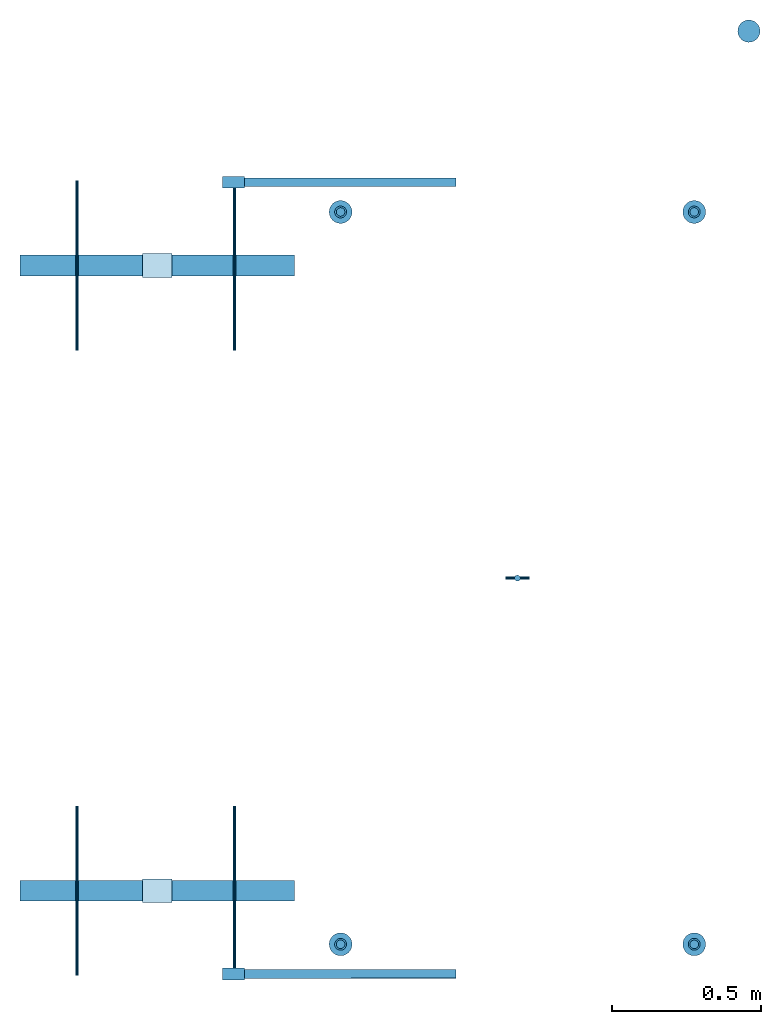
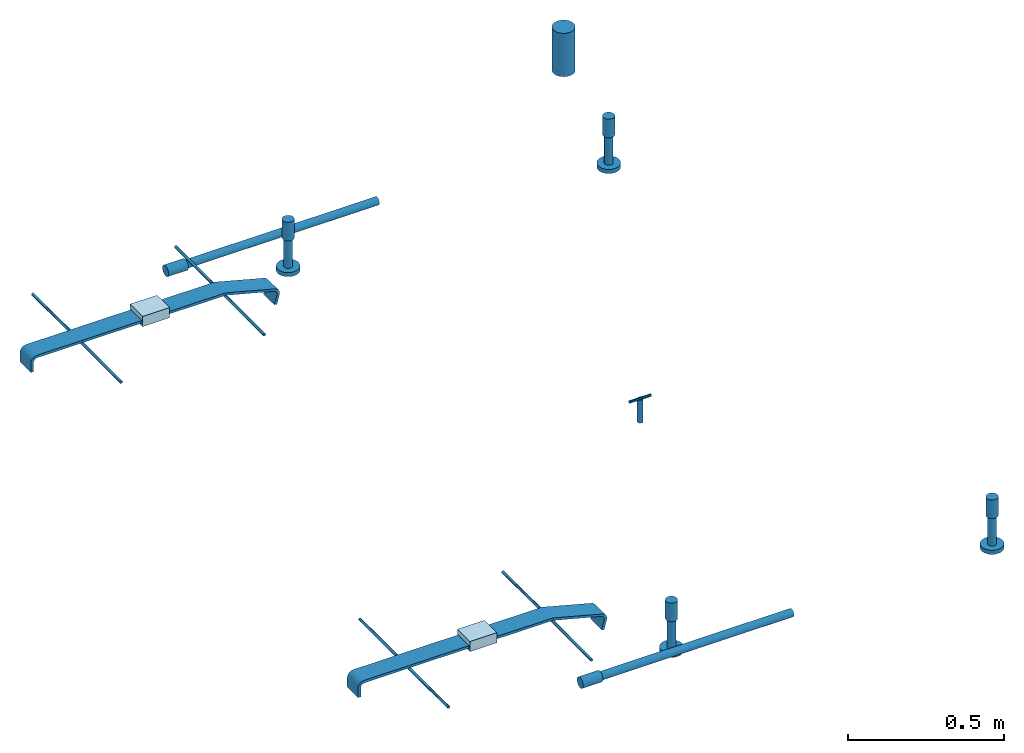
# One storey: 14 reinforcing bars, 6 columns, 5 discrete accessories, 2 beams, 2 plates, 10 elements without a shape of their own.
"""IFC2X3 building model written with IfcOpenShell, lengths in millimetres."""

from ifc_helpers import new_model, entity, si_unit, frame, frame_2d, origin_with_axes, origin_2d_with_axis, place, context, subcontext, project, spatial, polyline, circle_curve, parameter, trimmed, segment, composite_curve, circle, outline, extrude, source, transform, mapped, material, type_object, element, aggregate, save


model = new_model("IFC2X3")

# Units and contexts
model_context = context("Model", 3, precision=1e-05, world=origin_with_axes())
body_context = subcontext(model_context, "Body", "Model", "MODEL_VIEW")
ifc_project = project(units=[si_unit("LENGTHUNIT", "METRE", prefix="MILLI"), si_unit("AREAUNIT", "SQUARE_METRE"), si_unit("VOLUMEUNIT", "CUBIC_METRE"), si_unit("MASSUNIT", "GRAM", prefix="KILO"), si_unit("TIMEUNIT", "SECOND"), si_unit("PLANEANGLEUNIT", "RADIAN"), si_unit("SOLIDANGLEUNIT", "STERADIAN"), si_unit("THERMODYNAMICTEMPERATUREUNIT", "DEGREE_CELSIUS"), si_unit("LUMINOUSINTENSITYUNIT", "LUMEN")], contexts=[model_context])

# Site, building, storey
site_placement = place(None, origin_with_axes())
site = spatial("IfcSite", under=ifc_project, at=site_placement, CompositionType="ELEMENT")
building_placement = place(site_placement, origin_with_axes())
building = spatial("IfcBuilding", under=site, at=building_placement, Name="Undefined", CompositionType="ELEMENT")
storey_placement = place(building_placement, origin_with_axes())
storey = spatial("IfcBuildingStorey", under=building, at=storey_placement, Name="Undefined", CompositionType="ELEMENT", Elevation=0.0)

# Assembly, column
assembly_1_placement = place(storey_placement, origin_with_axes())
assembly_1 = element("IfcElementAssembly", 1, at=assembly_1_placement, inside=storey, Name="Steel Assembly", AssemblyPlace="NOTDEFINED", PredefinedType="RIGID_FRAME")
ifc_material_1 = material(Name="STEEL/Steel_Undefined")
column_type_1 = type_object("IfcColumnType", Name="D40", PredefinedType="NOTDEFINED")
column_1_placement = place(assembly_1_placement, frame((8784.0, 6820.0, -99.0000999999924), z_axis=(0.0, 0.0, 1.0), x_axis=(-0.895962645867593, -0.444129414934366, 0.0)))
column_1 = element("IfcColumn", 2, at=column_1_placement, type_object=column_type_1, material=ifc_material_1, Name="PLA30", ObjectType="D40", context=body_context, shape_type="SweptSolid", body=[
    extrude(circle(Radius=20.0, at=origin_2d_with_axis()), frame((0.0, -4.54747350886464e-13, 72.9999999999995), z_axis=(0.0, 0.0, -1.0), x_axis=(0.0, 1.0, 0.0)), (0.0, 0.0, 1.0), 73.0),
])

assembly_2_placement = place(storey_placement, origin_with_axes())
assembly_2 = element("IfcElementAssembly", 3, at=assembly_2_placement, inside=storey, Name="Steel Assembly", AssemblyPlace="NOTDEFINED", PredefinedType="RIGID_FRAME")
column_2_placement = place(assembly_2_placement, frame((7596.0, 6820.0, -87.0000999999942), z_axis=(0.0, 0.0, 1.0), x_axis=(-0.904917903898717, 0.425586168952366, 0.0)))
column_2 = element("IfcColumn", 4, at=column_2_placement, type_object=column_type_1, material=ifc_material_1, Name="PLA30", ObjectType="D40", context=body_context, shape_type="SweptSolid", body=[
    extrude(circle(Radius=20.0, at=origin_2d_with_axis()), frame((0.0, -4.54747350886464e-13, 72.9999999999995), z_axis=(0.0, 0.0, -1.0), x_axis=(0.0, 1.0, 0.0)), (0.0, 0.0, 1.0), 73.0),
])

assembly_3_placement = place(storey_placement, origin_with_axes())
assembly_3 = element("IfcElementAssembly", 5, at=assembly_3_placement, inside=storey, Name="Steel Assembly", AssemblyPlace="NOTDEFINED", PredefinedType="RIGID_FRAME")
column_3_placement = place(assembly_3_placement, frame((8784.0, 9280.0, -99.0000999999924), z_axis=(0.0, 0.0, 1.0), x_axis=(0.896017803814749, -0.4440181249082, 0.0)))
column_3 = element("IfcColumn", 6, at=column_3_placement, type_object=column_type_1, material=ifc_material_1, Name="PLA30", ObjectType="D40", context=body_context, shape_type="SweptSolid", body=[
    extrude(circle(Radius=20.0, at=origin_2d_with_axis()), frame((0.0, -4.54747350886464e-13, 72.9999999999995), z_axis=(0.0, 0.0, -1.0), x_axis=(0.0, 1.0, 0.0)), (0.0, 0.0, 1.0), 73.0),
])

assembly_4_placement = place(storey_placement, origin_with_axes())
assembly_4 = element("IfcElementAssembly", 7, at=assembly_4_placement, inside=storey, Name="Steel Assembly", AssemblyPlace="NOTDEFINED", PredefinedType="RIGID_FRAME")
column_4_placement = place(assembly_4_placement, frame((7596.0, 9280.0, -87.0000999999942), z_axis=(0.0, 0.0, 1.0), x_axis=(0.904969058279665, 0.425477383131485, 0.0)))
column_4 = element("IfcColumn", 8, at=column_4_placement, type_object=column_type_1, material=ifc_material_1, Name="PLA30", ObjectType="D40", context=body_context, shape_type="SweptSolid", body=[
    extrude(circle(Radius=20.0, at=origin_2d_with_axis()), frame((0.0, -4.54747350886464e-13, 72.9999999999995), z_axis=(0.0, 0.0, -1.0), x_axis=(0.0, 1.0, 0.0)), (0.0, 0.0, 1.0), 73.0),
])

assembly_5_placement = place(storey_placement, origin_with_axes())
assembly_5 = element("IfcElementAssembly", 9, at=assembly_5_placement, inside=storey, Name="Steel Assembly", AssemblyPlace="NOTDEFINED", PredefinedType="RIGID_FRAME")
ifc_material_2 = material(Name="STEEL/1.4305")
column_type_2 = type_object("IfcColumnType", Name="D20", PredefinedType="NOTDEFINED")
column_5_placement = place(assembly_5_placement, frame((8190.0, 8050.0, -270.0), z_axis=(0.0, 0.0, 1.0), x_axis=(0.0, 1.0, 0.0)))
column_5 = element("IfcColumn", 10, at=column_5_placement, type_object=column_type_2, material=ifc_material_2, Name="M16x90", ObjectType="D20", context=body_context, shape_type="SweptSolid", body=[
    extrude(circle(Radius=10.0, at=origin_2d_with_axis()), frame((0.0, 0.0, 90.0), z_axis=(0.0, 0.0, -1.0), x_axis=(0.0, 1.0, 0.0)), (0.0, 0.0, 1.0), 90.0),
])

assembly_6_placement = place(storey_placement, origin_with_axes())
assembly_6 = element("IfcElementAssembly", 11, at=assembly_6_placement, inside=storey, Name="Steel Assembly", AssemblyPlace="NOTDEFINED", PredefinedType="RIGID_FRAME")
ifc_material_3 = material(Name="STEEL/1.4301")
column_type_3 = type_object("IfcColumnType", Name="D75", PredefinedType="NOTDEFINED")
column_6_placement = place(assembly_6_placement, frame((8967.49878393828, 9887.49662337208, -280.054915765766), z_axis=(-2.04100000067167e-05, -2.86890000063952e-05, 0.999999999380187), x_axis=(0.981183268554412, 0.193078721912338, 2.55651859878299e-05)))
column_6 = element("IfcColumn", 12, at=column_6_placement, type_object=column_type_3, material=ifc_material_3, Name="83/75", ObjectType="D75", context=body_context, shape_type="SweptSolid", body=[
    extrude(circle(Radius=37.5, at=origin_2d_with_axis()), frame((-1.81898940354586e-12, -1.72790510903002e-18, 169.995857759637), z_axis=(0.0, 0.0, -1.0), x_axis=(0.0, 1.0, 0.0)), (0.0, 0.0, 1.0), 170.0),
])
aggregate(assembly_6, [column_6])

# Assembly, beam
assembly_7_placement = place(storey_placement, origin_with_axes())
assembly_7 = element("IfcElementAssembly", 13, at=assembly_7_placement, inside=storey, Name="Steel Assembly", AssemblyPlace="NOTDEFINED", PredefinedType="RIGID_FRAME")
beam_type = type_object("IfcBeamType", Name="D40", PredefinedType="NOTDEFINED")
beam_1_placement = place(assembly_7_placement, frame((7272.9993687735, 9380.02551493117, -140.00442402613), z_axis=(1.19564911619818e-06, 2.6939999552269e-06, 0.999999999995656), x_axis=(-0.999999991516754, -0.000130249999939832, 1.19599999947828e-06)))
beam_1 = element("IfcBeam", 14, at=beam_1_placement, type_object=beam_type, material=ifc_material_1, Name="PLA30P RST", ObjectType="D40", context=body_context, shape_type="SweptSolid", body=[
    extrude(circle(Radius=20.0, at=origin_2d_with_axis()), frame((73.000000000254, -8.95263087333074e-19, 0.0), z_axis=(-1.0, 1.22638779086296e-20, 0.0), x_axis=(1.2058821935041e-20, -1.0, -4.2351647362715e-22)), (0.0, 0.0, 1.0), 73.0),
])

assembly_8_placement = place(storey_placement, origin_with_axes())
assembly_8 = element("IfcElementAssembly", 15, at=assembly_8_placement, inside=storey, Name="Steel Assembly", AssemblyPlace="NOTDEFINED", PredefinedType="RIGID_FRAME")
beam_2_placement = place(assembly_8_placement, frame((7272.99936877345, 6720.02551493114, -140.004424026123), z_axis=(1.19564911619818e-06, 2.6939999552269e-06, 0.999999999995656), x_axis=(-0.999999991516754, -0.000130249999939832, 1.19599999947828e-06)))
beam_2 = element("IfcBeam", 16, at=beam_2_placement, type_object=beam_type, material=ifc_material_1, Name="PLA30P RST", ObjectType="D40", context=body_context, shape_type="SweptSolid", body=[
    extrude(circle(Radius=20.0, at=origin_2d_with_axis()), frame((73.000000000254, -8.95263087333074e-19, 0.0), z_axis=(-1.0, 1.22638779086296e-20, 0.0), x_axis=(1.2058821935041e-20, -1.0, -4.2351647362715e-22)), (0.0, 0.0, 1.0), 73.0),
])

# Assembly, plate
assembly_9_placement = place(storey_placement, origin_with_axes())
assembly_9 = element("IfcElementAssembly", 17, at=assembly_9_placement, inside=storey, Name="Steel Assembly", AssemblyPlace="NOTDEFINED", PredefinedType="RIGID_FRAME")
plate_type = type_object("IfcPlateType", Name="PL80X40", PredefinedType="NOTDEFINED")
plate_1_placement = place(assembly_9_placement, frame((7030.0, 9100.0, -69.9999999999964), z_axis=(1.2058821935041e-20, -1.0, -4.2351647362715e-22), x_axis=(0.0, 0.0, 1.0)))
plate_1 = element("IfcPlate", 18, at=plate_1_placement, type_object=plate_type, material=ifc_material_1, Name="PS230", ObjectType="PL80X40", context=body_context, shape_type="SweptSolid", body=[
    extrude(outline(polyline([(0.0, 0.0), (40.0, 0.0), (40.0, 100.0), (0.0, 100.0), (0.0, 0.0)])), frame((0.0, 0.0, -40.0), z_axis=(0.0, 0.0, 1.0), x_axis=(1.0, 0.0, 0.0)), (0.0, 0.0, 1.0), 80.0),
])

assembly_10_placement = place(storey_placement, origin_with_axes())
assembly_10 = element("IfcElementAssembly", 19, at=assembly_10_placement, inside=storey, Name="Steel Assembly", AssemblyPlace="NOTDEFINED", PredefinedType="RIGID_FRAME")
plate_2_placement = place(assembly_10_placement, frame((7030.0, 7000.0, -69.9999999999964), z_axis=(1.2058821935041e-20, -1.0, -4.2351647362715e-22), x_axis=(0.0, 0.0, 1.0)))
plate_2 = element("IfcPlate", 20, at=plate_2_placement, type_object=plate_type, material=ifc_material_1, Name="PS230", ObjectType="PL80X40", context=body_context, shape_type="SweptSolid", body=[
    extrude(outline(polyline([(0.0, 0.0), (40.0, 0.0), (40.0, 100.0), (0.0, 100.0), (0.0, 0.0)])), frame((0.0, 0.0, -40.0), z_axis=(0.0, 0.0, 1.0), x_axis=(1.0, 0.0, 0.0)), (0.0, 0.0, 1.0), 80.0),
])

# Reinforcing bar
ifc_material_4 = material(Name="Undefined")
shared_shape_1 = source(origin_with_axes(), body_context, "Body", "AdvancedSweptSolid", [
    entity("IfcSweptDiskSolid", entity("IfcTrimmedCurve", entity("IfcLine", entity("IfcCartesianPoint", [0.0, 0.0, 0.0]), entity("IfcVector", entity("IfcDirection", [1.0, 0.0, 0.0]), 1.0)), [entity("IfcParameterValue", 0.0)], [entity("IfcParameterValue", 711.000000000276)], True, "PARAMETER"), 14.5, None, 0.0, 711.000000000276),
])
reinforcing_bar_1_placement = place(assembly_7_placement, frame((7272.99936895076, 9380.02468352953, -140.003886127926), z_axis=(0.000130155301525519, -0.999548757077827, -0.0300377310023403), x_axis=(0.999999991516754, 0.000130249999937964, -1.19599999942144e-06)))
reinforcing_bar_1 = element("IfcReinforcingBar", 21, at=reinforcing_bar_1_placement, material=ifc_material_4, Name="REBAR", BarRole="NOTDEFINED", CrossSectionArea=0.0, NominalDiameter=29.0, context=body_context, shape_type="MappedRepresentation", body=[
    mapped(shared_shape_1, transform((0.0, 0.0, 0.0))),
])

aggregate(assembly_7, [beam_1, reinforcing_bar_1])

shared_shape_2 = source(origin_with_axes(), body_context, "Body", "AdvancedSweptSolid", [
    entity("IfcSweptDiskSolid", entity("IfcTrimmedCurve", entity("IfcLine", entity("IfcCartesianPoint", [0.0, 0.0, 0.0]), entity("IfcVector", entity("IfcDirection", [1.0, 0.0, 0.0]), 1.0)), [entity("IfcParameterValue", 0.0)], [entity("IfcParameterValue", 111.0)], True, "PARAMETER"), 14.5, None, 0.0, 111.0),
])
reinforcing_bar_2_placement = place(assembly_1_placement, frame((8784.0, 6820.0, -99.0000999999924), z_axis=(0.444129414934365, -0.895962645867593, 0.0), x_axis=(0.0, 0.0, -1.0)))
reinforcing_bar_2 = element("IfcReinforcingBar", 22, at=reinforcing_bar_2_placement, material=ifc_material_4, Name="REBAR", BarRole="NOTDEFINED", CrossSectionArea=0.0, NominalDiameter=29.0, context=body_context, shape_type="MappedRepresentation", body=[
    mapped(shared_shape_2, transform((0.0, 0.0, 0.0))),
])

shared_shape_3 = source(origin_with_axes(), body_context, "Body", "AdvancedSweptSolid", [
    entity("IfcSweptDiskSolid", entity("IfcTrimmedCurve", entity("IfcLine", entity("IfcCartesianPoint", [0.0, 0.0, 0.0]), entity("IfcVector", entity("IfcDirection", [1.0, 0.0, 0.0]), 1.0)), [entity("IfcParameterValue", 0.0)], [entity("IfcParameterValue", 16.0)], True, "PARAMETER"), 38.5, None, 0.0, 16.0),
])
reinforcing_bar_3_placement = place(assembly_1_placement, frame((8784.0, 6820.0, -226.000099999992), z_axis=(-0.444129414934365, 0.895962645867593, 0.0), x_axis=(0.0, 0.0, 1.0)))
reinforcing_bar_3 = element("IfcReinforcingBar", 23, at=reinforcing_bar_3_placement, material=ifc_material_4, Name="REBAR", BarRole="NOTDEFINED", CrossSectionArea=0.0, NominalDiameter=77.0, context=body_context, shape_type="MappedRepresentation", body=[
    mapped(shared_shape_3, transform((0.0, 0.0, 0.0))),
])

aggregate(assembly_1, [column_1, reinforcing_bar_2, reinforcing_bar_3])

shared_shape_4 = source(origin_with_axes(), body_context, "Body", "AdvancedSweptSolid", [
    entity("IfcSweptDiskSolid", entity("IfcTrimmedCurve", entity("IfcLine", entity("IfcCartesianPoint", [0.0, 0.0, 0.0]), entity("IfcVector", entity("IfcDirection", [1.0, 0.0, 0.0]), 1.0)), [entity("IfcParameterValue", 0.0)], [entity("IfcParameterValue", 111.0)], True, "PARAMETER"), 14.5, None, 0.0, 111.0),
])
reinforcing_bar_4_placement = place(assembly_2_placement, frame((7596.0, 6820.0, -87.0000999999942), z_axis=(-0.425586168952366, -0.904917903898717, 0.0), x_axis=(0.0, 0.0, -1.0)))
reinforcing_bar_4 = element("IfcReinforcingBar", 24, at=reinforcing_bar_4_placement, material=ifc_material_4, Name="REBAR", BarRole="NOTDEFINED", CrossSectionArea=0.0, NominalDiameter=29.0, context=body_context, shape_type="MappedRepresentation", body=[
    mapped(shared_shape_4, transform((0.0, 0.0, 0.0))),
])

shared_shape_5 = source(origin_with_axes(), body_context, "Body", "AdvancedSweptSolid", [
    entity("IfcSweptDiskSolid", entity("IfcTrimmedCurve", entity("IfcLine", entity("IfcCartesianPoint", [0.0, 0.0, 0.0]), entity("IfcVector", entity("IfcDirection", [1.0, 0.0, 0.0]), 1.0)), [entity("IfcParameterValue", 0.0)], [entity("IfcParameterValue", 16.0)], True, "PARAMETER"), 38.5, None, 0.0, 16.0),
])
reinforcing_bar_5_placement = place(assembly_2_placement, frame((7596.0, 6820.0, -214.000099999994), z_axis=(0.425586168952366, 0.904917903898717, 0.0), x_axis=(0.0, 0.0, 1.0)))
reinforcing_bar_5 = element("IfcReinforcingBar", 25, at=reinforcing_bar_5_placement, material=ifc_material_4, Name="REBAR", BarRole="NOTDEFINED", CrossSectionArea=0.0, NominalDiameter=77.0, context=body_context, shape_type="MappedRepresentation", body=[
    mapped(shared_shape_5, transform((0.0, 0.0, 0.0))),
])

aggregate(assembly_2, [column_2, reinforcing_bar_4, reinforcing_bar_5])

shared_shape_6 = source(origin_with_axes(), body_context, "Body", "AdvancedSweptSolid", [
    entity("IfcSweptDiskSolid", entity("IfcTrimmedCurve", entity("IfcLine", entity("IfcCartesianPoint", [0.0, 0.0, 0.0]), entity("IfcVector", entity("IfcDirection", [1.0, 0.0, 0.0]), 1.0)), [entity("IfcParameterValue", 0.0)], [entity("IfcParameterValue", 111.0)], True, "PARAMETER"), 14.5, None, 0.0, 111.0),
])
reinforcing_bar_6_placement = place(assembly_3_placement, frame((8784.0, 9280.0, -99.0000999999924), z_axis=(0.4440181249082, 0.896017803814749, 0.0), x_axis=(0.0, 0.0, -1.0)))
reinforcing_bar_6 = element("IfcReinforcingBar", 26, at=reinforcing_bar_6_placement, material=ifc_material_4, Name="REBAR", BarRole="NOTDEFINED", CrossSectionArea=0.0, NominalDiameter=29.0, context=body_context, shape_type="MappedRepresentation", body=[
    mapped(shared_shape_6, transform((0.0, 0.0, 0.0))),
])

shared_shape_7 = source(origin_with_axes(), body_context, "Body", "AdvancedSweptSolid", [
    entity("IfcSweptDiskSolid", entity("IfcTrimmedCurve", entity("IfcLine", entity("IfcCartesianPoint", [0.0, 0.0, 0.0]), entity("IfcVector", entity("IfcDirection", [1.0, 0.0, 0.0]), 1.0)), [entity("IfcParameterValue", 0.0)], [entity("IfcParameterValue", 16.0)], True, "PARAMETER"), 38.5, None, 0.0, 16.0),
])
reinforcing_bar_7_placement = place(assembly_3_placement, frame((8784.0, 9280.0, -226.000099999992), z_axis=(-0.4440181249082, -0.896017803814749, 0.0), x_axis=(0.0, 0.0, 1.0)))
reinforcing_bar_7 = element("IfcReinforcingBar", 27, at=reinforcing_bar_7_placement, material=ifc_material_4, Name="REBAR", BarRole="NOTDEFINED", CrossSectionArea=0.0, NominalDiameter=77.0, context=body_context, shape_type="MappedRepresentation", body=[
    mapped(shared_shape_7, transform((0.0, 0.0, 0.0))),
])

aggregate(assembly_3, [column_3, reinforcing_bar_6, reinforcing_bar_7])

shared_shape_8 = source(origin_with_axes(), body_context, "Body", "AdvancedSweptSolid", [
    entity("IfcSweptDiskSolid", entity("IfcTrimmedCurve", entity("IfcLine", entity("IfcCartesianPoint", [0.0, 0.0, 0.0]), entity("IfcVector", entity("IfcDirection", [1.0, 0.0, 0.0]), 1.0)), [entity("IfcParameterValue", 0.0)], [entity("IfcParameterValue", 111.0)], True, "PARAMETER"), 14.5, None, 0.0, 111.0),
])
reinforcing_bar_8_placement = place(assembly_4_placement, frame((7596.0, 9280.0, -87.0000999999942), z_axis=(-0.425477383131486, 0.904969058279664, 0.0), x_axis=(0.0, 0.0, -1.0)))
reinforcing_bar_8 = element("IfcReinforcingBar", 28, at=reinforcing_bar_8_placement, material=ifc_material_4, Name="REBAR", BarRole="NOTDEFINED", CrossSectionArea=0.0, NominalDiameter=29.0, context=body_context, shape_type="MappedRepresentation", body=[
    mapped(shared_shape_8, transform((0.0, 0.0, 0.0))),
])

shared_shape_9 = source(origin_with_axes(), body_context, "Body", "AdvancedSweptSolid", [
    entity("IfcSweptDiskSolid", entity("IfcTrimmedCurve", entity("IfcLine", entity("IfcCartesianPoint", [0.0, 0.0, 0.0]), entity("IfcVector", entity("IfcDirection", [1.0, 0.0, 0.0]), 1.0)), [entity("IfcParameterValue", 0.0)], [entity("IfcParameterValue", 16.0)], True, "PARAMETER"), 38.5, None, 0.0, 16.0),
])
reinforcing_bar_9_placement = place(assembly_4_placement, frame((7596.0, 9280.0, -214.000099999994), z_axis=(0.425477383131486, -0.904969058279664, 0.0), x_axis=(0.0, 0.0, 1.0)))
reinforcing_bar_9 = element("IfcReinforcingBar", 29, at=reinforcing_bar_9_placement, material=ifc_material_4, Name="REBAR", BarRole="NOTDEFINED", CrossSectionArea=0.0, NominalDiameter=77.0, context=body_context, shape_type="MappedRepresentation", body=[
    mapped(shared_shape_9, transform((0.0, 0.0, 0.0))),
])

aggregate(assembly_4, [column_4, reinforcing_bar_8, reinforcing_bar_9])

shared_shape_10 = source(origin_with_axes(), body_context, "Body", "AdvancedSweptSolid", [
    entity("IfcSweptDiskSolid", entity("IfcTrimmedCurve", entity("IfcLine", entity("IfcCartesianPoint", [0.0, 0.0, 0.0]), entity("IfcVector", entity("IfcDirection", [1.0, 0.0, 0.0]), 1.0)), [entity("IfcParameterValue", 0.0)], [entity("IfcParameterValue", 711.000000000277)], True, "PARAMETER"), 14.5, None, 0.0, 711.000000000277),
])
reinforcing_bar_10_placement = place(assembly_8_placement, frame((7272.9993689507, 6720.0246835295, -140.003886127918), z_axis=(0.000130155301525519, -0.999548757077827, -0.0300377310023403), x_axis=(0.999999991516754, 0.000130249999937964, -1.19599999942144e-06)))
reinforcing_bar_10 = element("IfcReinforcingBar", 30, at=reinforcing_bar_10_placement, material=ifc_material_4, Name="REBAR", BarRole="NOTDEFINED", CrossSectionArea=0.0, NominalDiameter=29.0, context=body_context, shape_type="MappedRepresentation", body=[
    mapped(shared_shape_10, transform((0.0, 0.0, 0.0))),
])

aggregate(assembly_8, [beam_2, reinforcing_bar_10])

# Discrete accessory
discrete_accessory_type_1 = type_object("IfcDiscreteAccessoryType", Name="DUMMY")
discrete_accessory_1_placement = place(assembly_5_placement, frame((8230.0, 8050.0, -180.0), z_axis=(0.0, 1.0, 0.0), x_axis=(-1.0, 1.22638779086296e-20, 0.0)))
discrete_accessory_1 = element("IfcDiscreteAccessory", 31, at=discrete_accessory_1_placement, type_object=discrete_accessory_type_1, material=ifc_material_2, Name="DUMMY", ObjectType="D10", context=body_context, shape_type="SweptSolid", body=[
    extrude(circle(Radius=5.0, at=origin_2d_with_axis()), frame((80.0, 0.0, 0.0), z_axis=(-1.0, 1.22638779086296e-20, 0.0), x_axis=(1.2058821935041e-20, -1.0, -4.2351647362715e-22)), (0.0, 0.0, 1.0), 80.0),
])

aggregate(assembly_5, [discrete_accessory_1, column_5])

discrete_accessory_type_2 = type_object("IfcDiscreteAccessoryType", Name="PS200")
discrete_accessory_2_placement = place(assembly_9_placement, frame((6940.0, 9100.0, -48.9999999999982), z_axis=(1.2058821935041e-20, -1.0, -4.2351647362715e-22), x_axis=(-1.0, 1.22638779086296e-20, 0.0)))
discrete_accessory_2 = element("IfcDiscreteAccessory", 32, at=discrete_accessory_2_placement, type_object=discrete_accessory_type_2, material=ifc_material_1, Name="PS200", ObjectType="PL70X60", context=body_context, shape_type="SweptSolid", body=[
    extrude(outline(composite_curve([segment(polyline([(0.0, 0.0), (398.0, 6.87845874214966e-12)]), True, "CONTINUOUS"), segment(trimmed(circle_curve(frame_2d((398.0, 23.0000000000069), x_axis=(1.4828717963689e-14, -1.0)), 23.0), [parameter(0.0)], [parameter(1.57079632679488)], True, "PARAMETER"), True, "CONTINUOUS"), segment(polyline([(421.0, 23.0000000000069), (421.0, 60.0), (411.0, 60.0), (411.0, 25.0)]), True, "CONTINUOUS"), segment(trimmed(circle_curve(frame_2d((396.0, 25.0), x_axis=(1.0, 0.0)), 15.0), [parameter(0.0)], [parameter(4.71238898038469)], False, "PARAMETER"), True, "CONTINUOUS"), segment(polyline([(396.0, 10.0), (0.0, 10.0), (0.0, 0.0)]), True, "CONTINUOUS")], self_intersect=True)), frame((0.0, 0.0, -35.0), z_axis=(0.0, 0.0, 1.0), x_axis=(1.0, 0.0, 0.0)), (0.0, 0.0, 1.0), 70.0),
])

discrete_accessory_3_placement = place(assembly_9_placement, frame((7445.97000094325, 9100.0, -103.76005441519), z_axis=(1.2058821935041e-20, -1.0, -4.2351647362715e-22), x_axis=(-0.966544292860371, 0.0, 0.256499765962945)))
discrete_accessory_3 = element("IfcDiscreteAccessory", 33, at=discrete_accessory_3_placement, type_object=discrete_accessory_type_2, material=ifc_material_1, Name="PS200", ObjectType="PL70X113", context=body_context, shape_type="SweptSolid", body=[
    extrude(outline(composite_curve([segment(trimmed(circle_curve(frame_2d((23.0400457468528, 23.0000000000025), x_axis=(-0.99999848688837, 0.00173960368224458)), 23.0), [parameter(0.0)], [parameter(1.57253593135466)], True, "PARAMETER"), True, "CONTINUOUS"), segment(polyline([(23.0400457468554, 2.5566696094284e-12), (213.099411011284, 2.36468622460961e-11), (425.739166260862, 56.4299736023818), (423.17416381945, 66.0954132080931), (210.534408569874, 9.66544055943109), (25.1344495065232, 8.76145037309022)]), True, "CONTINUOUS"), segment(trimmed(circle_curve(frame_2d((25.0613119951757, 23.7612720688449), x_axis=(0.00487583408983478, -0.999988113050314)), 15.0), [parameter(0.0)], [parameter(4.7066116804416)], False, "PARAMETER"), True, "CONTINUOUS"), segment(polyline([(10.0613180897192, 23.7747937650171), (10.0939512253171, 59.9756393432585), (0.104437835525459, 60.0353279113717), (0.0400805484203027, 23.0400108846942)]), True, "CONTINUOUS")], self_intersect=True)), frame((0.0, 0.0, -35.0), z_axis=(0.0, 0.0, 1.0), x_axis=(1.0, 0.0, 0.0)), (0.0, 0.0, 1.0), 70.0),
])

discrete_accessory_4_placement = place(assembly_10_placement, frame((6940.0, 7000.0, -48.9999999999982), z_axis=(1.2058821935041e-20, -1.0, -4.2351647362715e-22), x_axis=(-1.0, 1.22638779086296e-20, 0.0)))
discrete_accessory_4 = element("IfcDiscreteAccessory", 34, at=discrete_accessory_4_placement, type_object=discrete_accessory_type_2, material=ifc_material_1, Name="PS200", ObjectType="PL70X60", context=body_context, shape_type="SweptSolid", body=[
    extrude(outline(composite_curve([segment(polyline([(0.0, 0.0), (398.0, 6.87845874214966e-12)]), True, "CONTINUOUS"), segment(trimmed(circle_curve(frame_2d((398.0, 23.0000000000069), x_axis=(1.4828717963689e-14, -1.0)), 23.0), [parameter(0.0)], [parameter(1.57079632679488)], True, "PARAMETER"), True, "CONTINUOUS"), segment(polyline([(421.0, 23.0000000000069), (421.0, 60.0), (411.0, 60.0), (411.0, 25.0)]), True, "CONTINUOUS"), segment(trimmed(circle_curve(frame_2d((396.0, 25.0), x_axis=(1.0, 0.0)), 15.0), [parameter(0.0)], [parameter(4.71238898038469)], False, "PARAMETER"), True, "CONTINUOUS"), segment(polyline([(396.0, 10.0), (0.0, 10.0), (0.0, 0.0)]), True, "CONTINUOUS")], self_intersect=True)), frame((0.0, 0.0, -35.0), z_axis=(0.0, 0.0, 1.0), x_axis=(1.0, 0.0, 0.0)), (0.0, 0.0, 1.0), 70.0),
])

discrete_accessory_5_placement = place(assembly_10_placement, frame((7445.97000094325, 7000.0, -103.76005441519), z_axis=(1.2058821935041e-20, -1.0, -4.2351647362715e-22), x_axis=(-0.966544292860371, 0.0, 0.256499765962945)))
discrete_accessory_5 = element("IfcDiscreteAccessory", 35, at=discrete_accessory_5_placement, type_object=discrete_accessory_type_2, material=ifc_material_1, Name="PS200", ObjectType="PL70X113", context=body_context, shape_type="SweptSolid", body=[
    extrude(outline(composite_curve([segment(trimmed(circle_curve(frame_2d((23.0400457468528, 23.0000000000025), x_axis=(-0.99999848688837, 0.00173960368224458)), 23.0), [parameter(0.0)], [parameter(1.57253593135466)], True, "PARAMETER"), True, "CONTINUOUS"), segment(polyline([(23.0400457468554, 2.5566696094284e-12), (213.099411011284, 2.36468622460961e-11), (425.739166260862, 56.4299736023818), (423.17416381945, 66.0954132080931), (210.534408569874, 9.66544055943109), (25.1344495065232, 8.76145037309022)]), True, "CONTINUOUS"), segment(trimmed(circle_curve(frame_2d((25.0613119951757, 23.7612720688449), x_axis=(0.00487583408983478, -0.999988113050314)), 15.0), [parameter(0.0)], [parameter(4.7066116804416)], False, "PARAMETER"), True, "CONTINUOUS"), segment(polyline([(10.0613180897192, 23.7747937650171), (10.0939512253171, 59.9756393432585), (0.104437835525459, 60.0353279113717), (0.0400805484203027, 23.0400108846942)]), True, "CONTINUOUS")], self_intersect=True)), frame((0.0, 0.0, -35.0), z_axis=(0.0, 0.0, 1.0), x_axis=(1.0, 0.0, 0.0)), (0.0, 0.0, 1.0), 70.0),
])

# Reinforcing bar
shared_shape_11 = source(origin_with_axes(), body_context, "Body", "AdvancedSweptSolid", [
    entity("IfcSweptDiskSolid", entity("IfcTrimmedCurve", entity("IfcLine", entity("IfcCartesianPoint", [0.0, 0.0, 0.0]), entity("IfcVector", entity("IfcDirection", [1.0, 0.0, 0.0]), 1.0)), [entity("IfcParameterValue", 0.0)], [entity("IfcParameterValue", 570.000000000002)], True, "PARAMETER"), 5.0, None, 0.0, 570.000000000002),
])
reinforcing_bar_11_placement = place(assembly_9_placement, frame((6769.99677343954, 9135.0, -62.0), z_axis=(0.0, 0.0, -1.0), x_axis=(1.2058821935041e-20, -1.0, -4.2351647362715e-22)))
reinforcing_bar_11 = element("IfcReinforcingBar", 36, at=reinforcing_bar_11_placement, material=ifc_material_4, Name="REBAR", BarRole="NOTDEFINED", CrossSectionArea=0.0, NominalDiameter=10.0, context=body_context, shape_type="MappedRepresentation", body=[
    mapped(shared_shape_11, transform((-250.0, 60.0, 0.0))),
])

shared_shape_12 = source(origin_with_axes(), body_context, "Body", "AdvancedSweptSolid", [
    entity("IfcSweptDiskSolid", entity("IfcTrimmedCurve", entity("IfcLine", entity("IfcCartesianPoint", [0.0, 0.0, 0.0]), entity("IfcVector", entity("IfcDirection", [1.0, 0.0, 0.0]), 1.0)), [entity("IfcParameterValue", 0.0)], [entity("IfcParameterValue", 570.000000000002)], True, "PARAMETER"), 5.0, None, 0.0, 570.000000000002),
])
reinforcing_bar_12_placement = place(assembly_9_placement, frame((7179.99998475582, 9135.0, -62.2001041683143), z_axis=(0.0, 0.0, -1.0), x_axis=(1.2058821935041e-20, -1.0, -4.2351647362715e-22)))
reinforcing_bar_12 = element("IfcReinforcingBar", 37, at=reinforcing_bar_12_placement, material=ifc_material_4, Name="REBAR", BarRole="NOTDEFINED", CrossSectionArea=0.0, NominalDiameter=10.0, context=body_context, shape_type="MappedRepresentation", body=[
    mapped(shared_shape_12, transform((-250.0, -60.0, 0.0))),
])

aggregate(assembly_9, [discrete_accessory_2, reinforcing_bar_11, discrete_accessory_3, reinforcing_bar_12, plate_1])

shared_shape_13 = source(origin_with_axes(), body_context, "Body", "AdvancedSweptSolid", [
    entity("IfcSweptDiskSolid", entity("IfcTrimmedCurve", entity("IfcLine", entity("IfcCartesianPoint", [0.0, 0.0, 0.0]), entity("IfcVector", entity("IfcDirection", [1.0, 0.0, 0.0]), 1.0)), [entity("IfcParameterValue", 0.0)], [entity("IfcParameterValue", 570.000000000002)], True, "PARAMETER"), 5.0, None, 0.0, 570.000000000002),
])
reinforcing_bar_13_placement = place(assembly_10_placement, frame((6769.99677343954, 7035.0, -62.0), z_axis=(0.0, 0.0, -1.0), x_axis=(1.2058821935041e-20, -1.0, -4.2351647362715e-22)))
reinforcing_bar_13 = element("IfcReinforcingBar", 38, at=reinforcing_bar_13_placement, material=ifc_material_4, Name="REBAR", BarRole="NOTDEFINED", CrossSectionArea=0.0, NominalDiameter=10.0, context=body_context, shape_type="MappedRepresentation", body=[
    mapped(shared_shape_13, transform((-250.0, 60.0, 0.0))),
])

shared_shape_14 = source(origin_with_axes(), body_context, "Body", "AdvancedSweptSolid", [
    entity("IfcSweptDiskSolid", entity("IfcTrimmedCurve", entity("IfcLine", entity("IfcCartesianPoint", [0.0, 0.0, 0.0]), entity("IfcVector", entity("IfcDirection", [1.0, 0.0, 0.0]), 1.0)), [entity("IfcParameterValue", 0.0)], [entity("IfcParameterValue", 570.000000000002)], True, "PARAMETER"), 5.0, None, 0.0, 570.000000000002),
])
reinforcing_bar_14_placement = place(assembly_10_placement, frame((7179.99998475582, 7035.0, -62.2001041683143), z_axis=(0.0, 0.0, -1.0), x_axis=(1.2058821935041e-20, -1.0, -4.2351647362715e-22)))
reinforcing_bar_14 = element("IfcReinforcingBar", 39, at=reinforcing_bar_14_placement, material=ifc_material_4, Name="REBAR", BarRole="NOTDEFINED", CrossSectionArea=0.0, NominalDiameter=10.0, context=body_context, shape_type="MappedRepresentation", body=[
    mapped(shared_shape_14, transform((-250.0, -60.0, 0.0))),
])

aggregate(assembly_10, [discrete_accessory_4, reinforcing_bar_13, discrete_accessory_5, reinforcing_bar_14, plate_2])

save(model, "model.ifc")
